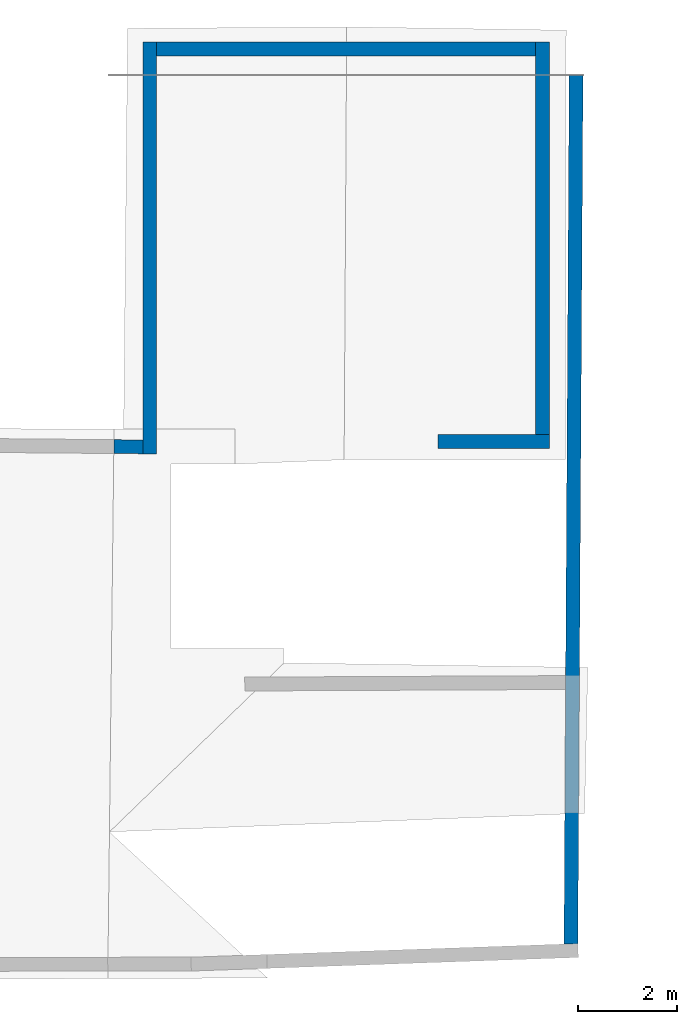
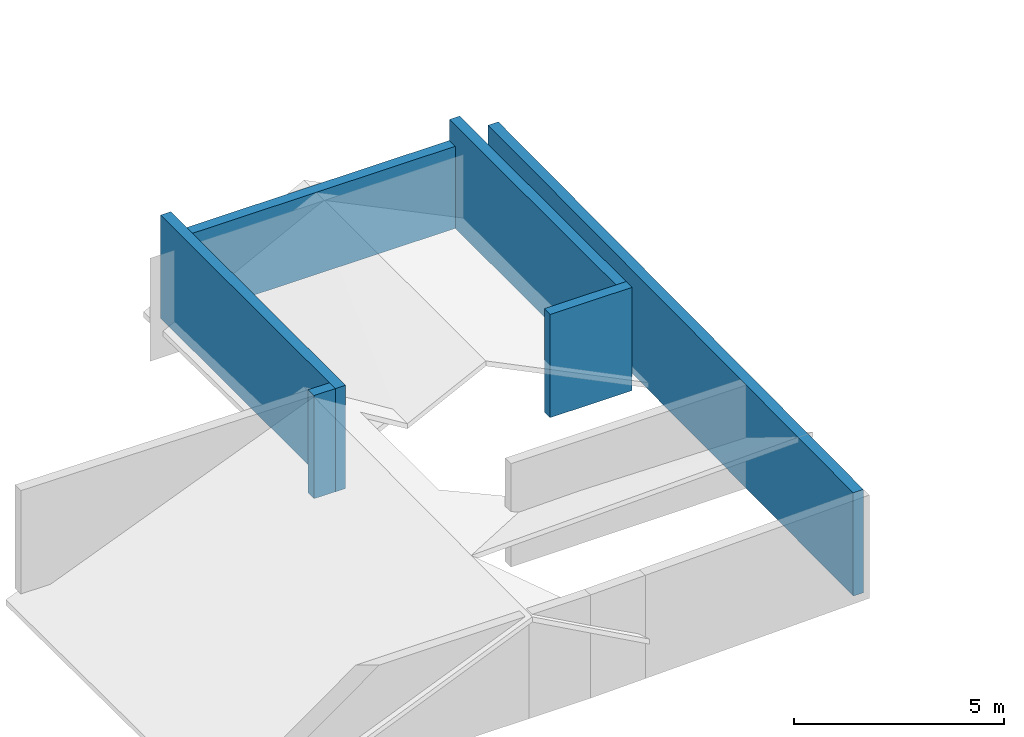
# One storey, part 2 of 4: 12 walls.
"""IFC4 building model written with IfcOpenShell, lengths in metres."""

from ifc_helpers import new_model, entity, si_unit, converted_unit, frame, frame_2d, origin_with_axes, place, context, subcontext, project, spatial, indexed_curve, outline, extrude, clip, halfspace, material, layer, layer_set, layer_usage, type_object, element, save


model = new_model("IFC4")

# Units and contexts
model_context = context("Model", 3, precision=1e-05, world=origin_with_axes())
plan_context = context("Plan", 2, precision=1e-05, world=frame_2d((0.0, 0.0, 0.0), x_axis=(1.0, 0.0, 0.0)))
body_context = subcontext(model_context, "Body", "Model", "MODEL_VIEW")
ifc_project = project(units=[converted_unit("PLANEANGLEUNIT", "degree", entity("IfcReal", 0.0174532925199433), si_unit("PLANEANGLEUNIT", "RADIAN"), dimensions=[0, 0, 0, 0, 0, 0, 0]), si_unit("AREAUNIT", "SQUARE_METRE"), si_unit("VOLUMEUNIT", "CUBIC_METRE"), si_unit("LENGTHUNIT", "METRE")], contexts=[model_context, plan_context])

# Site, building, storey
site_placement = place(None, origin_with_axes())
site = spatial("IfcSite", under=ifc_project, at=site_placement)
building_placement = place(site_placement, origin_with_axes())
building = spatial("IfcBuilding", under=site, at=building_placement, Name="Building")
storey_placement = place(building_placement, frame((0.0, 0.0, 3.0), z_axis=(0.0, 0.0, 1.0), x_axis=(1.0, 0.0, 0.0)))
storey = spatial("IfcBuildingStorey", under=building, at=storey_placement, Name="Dachgeschoss")

# Walls
ifc_material = material(Name="aussenwand_280_material")
ifc_layer = layer(ifc_material, 0.280000001192093)
ifc_layer_set = layer_set([ifc_layer])
ifc_layer_usage_1 = layer_usage(ifc_layer_set, "AXIS2", "POSITIVE", 0.0)
wall_type = type_object("IfcWallType", Name="aussenwand_280", PredefinedType="STANDARD", material=ifc_layer_set)
wall_1_placement = place(storey_placement, frame((9.18882751464844, 19.7012138366699, -2.38418579101563e-07), z_axis=(0.0, 0.0, 1.0), x_axis=(-1.62920684942947e-07, -1.0, 0.0)))
element("IfcWall", 1, at=wall_1_placement, inside=storey, type_object=wall_type, material=ifc_layer_usage_1, Name="Wall", PredefinedType="NOTDEFINED", context=body_context, shape_type="SweptSolid", body=[
    extrude(outline(indexed_curve([(0.0, 0.0), (0.0, 0.280000001192093), (8.31982420442171, 0.280000001192093), (8.31982420442171, 0.0), (0.0, 0.0)], self_intersect=False)), origin_with_axes(), (0.0, 0.0, 1.0), 3.0),
])
ifc_layer_usage_2 = layer_usage(ifc_layer_set, "AXIS2", "POSITIVE", 0.0)
wall_2_placement = place(storey_placement, frame((9.19131374359131, 11.6638669967651, -2.38418579101563e-07), z_axis=(0.0, 0.0, 1.0), x_axis=(-0.999960541725159, 0.00888374913483858, 0.0)))
element("IfcWall", 2, at=wall_2_placement, inside=storey, type_object=wall_type, material=ifc_layer_usage_2, Name="Wall", PredefinedType="NOTDEFINED", context=body_context, shape_type="SweptSolid", body=[
    extrude(outline(indexed_curve([(0.0, 0.0), (0.0, 0.280000001192093), (0.585232937038386, 0.280000001192093), (0.585232937038386, 0.0), (0.0, 0.0)], self_intersect=False)), origin_with_axes(), (0.0, 0.0, 1.0), 3.0),
])
ifc_layer_usage_3 = layer_usage(ifc_layer_set, "AXIS2", "POSITIVE", 0.0)
wall_3_placement = place(storey_placement, frame((9.46882724761963, 19.4212131500244, -2.38418579101563e-07), z_axis=(0.0, 0.0, 1.0), x_axis=(1.0, 0.0, 0.0)))
element("IfcWall", 3, at=wall_3_placement, inside=storey, type_object=wall_type, material=ifc_layer_usage_3, Name="Wall", PredefinedType="NOTDEFINED", context=body_context, shape_type="Clipping", body=[
    clip(extrude(outline(indexed_curve([(0.0, 0.0), (0.0, 0.280000001192093), (7.65666477870406, 0.280000001192093), (7.65666477870406, 0.0), (0.0, 0.0)], self_intersect=False)), origin_with_axes(), (0.0, 0.0, 1.0), 2.38790509447169), halfspace(frame((0.0, 0.0, -0.612094640731812), z_axis=(0.0, 0.0, 1.0), x_axis=(1.0, 0.0, 0.0)), False)),
])
ifc_layer_usage_4 = layer_usage(ifc_layer_set, "AXIS2", "POSITIVE", 0.0)
wall_4_placement = place(storey_placement, frame((15.1564960479736, 11.4919033050537, -2.38418579101563e-07), z_axis=(0.0, 0.0, 1.0), x_axis=(1.0, 0.0, 0.0)))
element("IfcWall", 4, at=wall_4_placement, inside=storey, type_object=wall_type, material=ifc_layer_usage_4, Name="Wall", PredefinedType="NOTDEFINED", context=body_context, shape_type="SweptSolid", body=[
    extrude(outline(indexed_curve([(0.0, 0.0), (0.0, 0.280000001192093), (2.24899481466534, 0.280000001192093), (2.24899481466534, 0.0), (0.0, 0.0)], self_intersect=False)), origin_with_axes(), (0.0, 0.0, 1.0), 3.0),
])
ifc_layer_usage_5 = layer_usage(ifc_layer_set, "AXIS2", "POSITIVE", 0.0)
wall_5_placement = place(storey_placement, frame((17.1254920959473, 19.7012138366699, -2.38418579101563e-07), z_axis=(0.0, 0.0, 1.0), x_axis=(-1.62920684942947e-07, -1.0, 0.0)))
element("IfcWall", 5, at=wall_5_placement, inside=storey, type_object=wall_type, material=ifc_layer_usage_5, Name="Wall", PredefinedType="NOTDEFINED", context=body_context, shape_type="SweptSolid", body=[
    extrude(outline(indexed_curve([(0.0, 0.0), (0.0, 0.280000001192093), (7.92931081694632, 0.280000001192093), (7.92931081694632, 0.0), (0.0, 0.0)], self_intersect=False)), origin_with_axes(), (0.0, 0.0, 1.0), 3.0),
])
ifc_layer_usage_6 = layer_usage(ifc_layer_set, "AXIS2", "POSITIVE", 0.0)
wall_6_placement = place(storey_placement, frame((17.8049087524414, 19.0355453491211, -2.38418579101562e-07), z_axis=(0.0, 0.0, 1.0), x_axis=(-0.00592900207266212, -0.999982416629791, 0.0)))
element("IfcWall", 6, at=wall_6_placement, inside=storey, type_object=wall_type, material=ifc_layer_usage_6, Name="Wall", PredefinedType="NOTDEFINED", context=body_context, shape_type="Clipping", body=[
    clip(extrude(outline(indexed_curve([(0.0, 0.0), (0.0, 0.280000001192093), (17.5594807033226, 0.280000001192093), (17.5594807033226, 0.0), (0.0, 0.0)], self_intersect=False)), origin_with_axes(), (0.0, 0.0, 1.0), 3.0), halfspace(frame((0.00166012346744537, 2.05636024475098e-06, -2.99999976158142), z_axis=(-0.839993059635162, -0.00498040812090039, 0.0), x_axis=(-0.00166013592388481, 0.279997676610947, 0.0)), False)),
])
ifc_layer_usage_7 = layer_usage(ifc_layer_set, "AXIS2", "POSITIVE", 0.0)
wall_7_placement = place(storey_placement, frame((9.46882724761963, 19.4212131500244, -2.38418579101563e-07), z_axis=(0.0, 0.0, 1.0), x_axis=(1.0, 0.0, 0.0)))
element("IfcWall", 7, at=wall_7_placement, inside=storey, type_object=wall_type, material=ifc_layer_usage_7, Name="Wall", PredefinedType="NOTDEFINED", context=body_context, shape_type="Clipping", body=[
    clip(extrude(outline(indexed_curve([(0.0, 0.0), (0.0, 0.280000001192093), (7.65666477870406, 0.280000001192093), (7.65666477870406, 0.0), (0.0, 0.0)], self_intersect=False)), origin_with_axes(), (0.0, 0.0, 1.0), 2.38790509447169), halfspace(frame((0.0, 0.0, -0.612094640731812), z_axis=(0.0, 0.0, 1.0), x_axis=(1.0, 0.0, 0.0)), False)),
])
ifc_layer_usage_8 = layer_usage(ifc_layer_set, "AXIS2", "POSITIVE", 0.0)
wall_8_placement = place(storey_placement, frame((17.8049087524414, 19.0355453491211, -2.38418579101562e-07), z_axis=(0.0, 0.0, 1.0), x_axis=(-0.00592900207266212, -0.999982416629791, 0.0)))
element("IfcWall", 8, at=wall_8_placement, inside=storey, type_object=wall_type, material=ifc_layer_usage_8, Name="Wall", PredefinedType="NOTDEFINED", context=body_context, shape_type="Clipping", body=[
    clip(extrude(outline(indexed_curve([(0.0, 0.0), (0.0, 0.280000001192093), (17.5594807033226, 0.280000001192093), (17.5594807033226, 0.0), (0.0, 0.0)], self_intersect=False)), origin_with_axes(), (0.0, 0.0, 1.0), 3.0), halfspace(frame((0.00166012346744537, 2.05636024475098e-06, -2.99999976158142), z_axis=(-0.839993059635162, -0.00498040812090039, 0.0), x_axis=(-0.00166013592388481, 0.279997676610947, 0.0)), False)),
])
ifc_layer_usage_9 = layer_usage(ifc_layer_set, "AXIS2", "POSITIVE", 0.0)
wall_9_placement = place(storey_placement, frame((9.19131374359131, 11.6638669967651, -2.38418579101563e-07), z_axis=(0.0, 0.0, 1.0), x_axis=(-0.999960541725159, 0.00888374913483858, 0.0)))
element("IfcWall", 9, at=wall_9_placement, inside=storey, type_object=wall_type, material=ifc_layer_usage_9, Name="Wall", PredefinedType="NOTDEFINED", context=body_context, shape_type="SweptSolid", body=[
    extrude(outline(indexed_curve([(0.0, 0.0), (0.0, 0.280000001192093), (0.585232937038386, 0.280000001192093), (0.585232937038386, 0.0), (0.0, 0.0)], self_intersect=False)), origin_with_axes(), (0.0, 0.0, 1.0), 3.0),
])
ifc_layer_usage_10 = layer_usage(ifc_layer_set, "AXIS2", "POSITIVE", 0.0)
wall_10_placement = place(storey_placement, frame((17.1254920959473, 19.7012138366699, -2.38418579101563e-07), z_axis=(0.0, 0.0, 1.0), x_axis=(-1.62920684942947e-07, -1.0, 0.0)))
element("IfcWall", 10, at=wall_10_placement, inside=storey, type_object=wall_type, material=ifc_layer_usage_10, Name="Wall", PredefinedType="NOTDEFINED", context=body_context, shape_type="SweptSolid", body=[
    extrude(outline(indexed_curve([(0.0, 0.0), (0.0, 0.280000001192093), (7.92931081694632, 0.280000001192093), (7.92931081694632, 0.0), (0.0, 0.0)], self_intersect=False)), origin_with_axes(), (0.0, 0.0, 1.0), 3.0),
])
ifc_layer_usage_11 = layer_usage(ifc_layer_set, "AXIS2", "POSITIVE", 0.0)
wall_11_placement = place(storey_placement, frame((9.18882751464844, 19.7012138366699, -2.38418579101563e-07), z_axis=(0.0, 0.0, 1.0), x_axis=(-1.62920684942947e-07, -1.0, 0.0)))
element("IfcWall", 11, at=wall_11_placement, inside=storey, type_object=wall_type, material=ifc_layer_usage_11, Name="Wall", PredefinedType="NOTDEFINED", context=body_context, shape_type="SweptSolid", body=[
    extrude(outline(indexed_curve([(0.0, 0.0), (0.0, 0.280000001192093), (8.31982420442171, 0.280000001192093), (8.31982420442171, 0.0), (0.0, 0.0)], self_intersect=False)), origin_with_axes(), (0.0, 0.0, 1.0), 3.0),
])
ifc_layer_usage_12 = layer_usage(ifc_layer_set, "AXIS2", "POSITIVE", 0.0)
wall_12_placement = place(storey_placement, frame((15.1564960479736, 11.4919033050537, -2.38418579101563e-07), z_axis=(0.0, 0.0, 1.0), x_axis=(1.0, 0.0, 0.0)))
element("IfcWall", 12, at=wall_12_placement, inside=storey, type_object=wall_type, material=ifc_layer_usage_12, Name="Wall", PredefinedType="NOTDEFINED", context=body_context, shape_type="SweptSolid", body=[
    extrude(outline(indexed_curve([(0.0, 0.0), (0.0, 0.280000001192093), (2.24899481466534, 0.280000001192093), (2.24899481466534, 0.0), (0.0, 0.0)], self_intersect=False)), origin_with_axes(), (0.0, 0.0, 1.0), 3.0),
])

save(model, "model.ifc")
